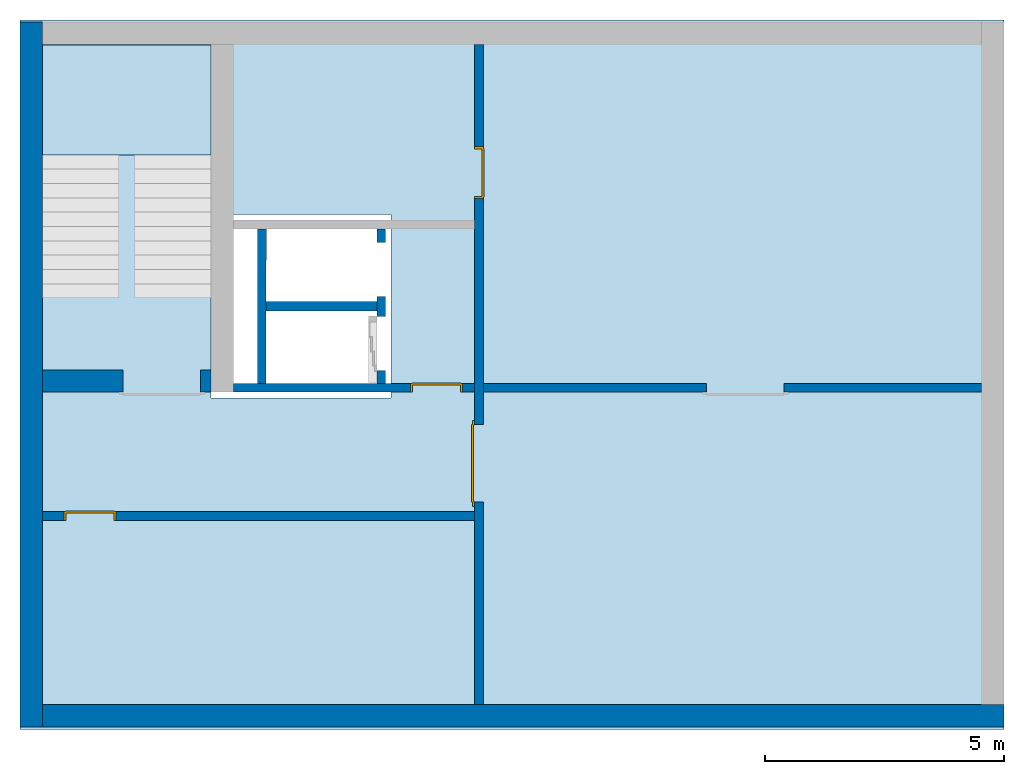
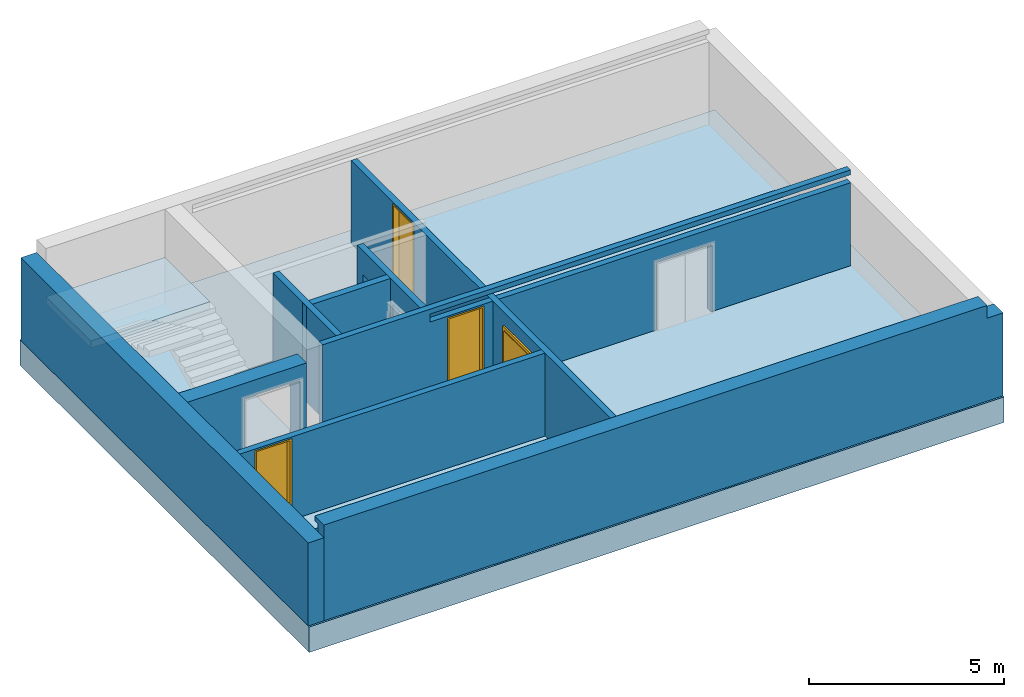
# One storey, part 1 of 3: 9 walls, 4 doors, 1 footing, 1 slab, 8 openings.
"""IFC4 building model written with IfcOpenShell, lengths in metres."""

from ifc_helpers import new_model, entity, si_unit, converted_unit, derived_unit, direction, frame, origin_with_axes, place, context, subcontext, project, spatial, polygons, source, transform, mapped, material, type_object, element, fill, save


model = new_model("IFC4")

# Units and contexts
model_context = context("Model", 3, precision=1e-05, world=origin_with_axes(), true_north=direction((0.0, 1.0)))
body_context = subcontext(model_context, "Body", "Model", "MODEL_VIEW")
ifc_project = project(units=[si_unit("LENGTHUNIT", "METRE"), si_unit("AREAUNIT", "SQUARE_METRE"), si_unit("VOLUMEUNIT", "CUBIC_METRE"), converted_unit("PLANEANGLEUNIT", "DEGREE", entity("IfcPlaneAngleMeasure", 0.0174532925199433), si_unit("PLANEANGLEUNIT", "RADIAN"), dimensions=[0, 0, 0, 0, 0, 0, 0]), converted_unit("TIMEUNIT", "Year", entity("IfcTimeMeasure", 31557600.0), si_unit("TIMEUNIT", "SECOND"), dimensions=[0, 0, 1, 0, 0, 0, 0]), si_unit("MASSUNIT", "GRAM", prefix="KILO"), si_unit("THERMODYNAMICTEMPERATUREUNIT", "DEGREE_CELSIUS"), si_unit("LUMINOUSINTENSITYUNIT", "LUMEN"), si_unit("ENERGYUNIT", "JOULE", prefix="MEGA"), derived_unit("THERMALCONDUCTANCEUNIT", [(si_unit("POWERUNIT", "WATT"), 1), (si_unit("LENGTHUNIT", "METRE"), -1), (si_unit("THERMODYNAMICTEMPERATUREUNIT", "KELVIN"), -1)]), derived_unit("SPECIFICHEATCAPACITYUNIT", [(si_unit("ENERGYUNIT", "JOULE"), 1), (si_unit("MASSUNIT", "GRAM", prefix="KILO"), -1), (si_unit("THERMODYNAMICTEMPERATUREUNIT", "KELVIN"), -1)]), derived_unit("MASSDENSITYUNIT", [(si_unit("MASSUNIT", "GRAM", prefix="KILO"), 1), (si_unit("VOLUMEUNIT", "CUBIC_METRE"), -1)])], contexts=[model_context])

# Site, building, storey
site_placement = place(None, origin_with_axes())
site = spatial("IfcSite", under=ifc_project, at=site_placement, CompositionType="ELEMENT")
building_placement = place(site_placement, origin_with_axes())
building = spatial("IfcBuilding", under=site, at=building_placement, CompositionType="ELEMENT")
storey_placement = place(building_placement, frame((0.0, 0.0, -3.0), z_axis=(0.0, 0.0, 1.0), x_axis=(1.0, 0.0, 0.0)))
storey = spatial("IfcBuildingStorey", under=building, at=storey_placement, Name="UG", CompositionType="ELEMENT", Elevation=-3.0)

# Footing
ifc_material_1 = material(Name="Stahlbeton Decke")
footing_type = type_object("IfcFootingType", Name="Stahlbeton Decke 800", PredefinedType="NOTDEFINED")
footing_placement = place(storey_placement, frame((44.584, 14.845999753475, 0.0), z_axis=(0.0, 0.0, 1.0), x_axis=(1.0, 0.0, 0.0)))
element("IfcFooting", 1, at=footing_placement, inside=storey, type_object=footing_type, material=ifc_material_1, Name="Decke-001", PredefinedType="NOTDEFINED", context=body_context, shape_type="Tessellation", body=[
    polygons([(0.0, 0.0, 0.0), (0.0, 0.0, -0.8), (-20.596, 0.0, -0.8), (-20.596, 0.0, 0.0), (0.0, -14.845999753475, 0.0), (0.0, -14.845999753475, -0.8), (-20.596, -14.845999753475, -0.8), (-12.826, -4.07099980800739, -0.8), (-16.5959999085664, -4.07099980800739, -0.8), (-16.5959999085664, -7.9109998080074, -0.8), (-12.826, -7.9109998080074, -0.8), (-20.596, -14.845999753475, 0.0), (-16.5959999085664, -7.9109998080074, 0.0), (-16.5959999085664, -4.07099980800739, 0.0), (-12.826, -4.07099980800739, 0.0), (-12.826, -7.9109998080074, 0.0)], [[[1, 2, 3, 4]], [[5, 6, 2, 1]], [[3, 2, 6, 7], [8, 9, 10, 11]], [[4, 3, 7, 12]], [[5, 1, 4, 12], [13, 14, 15, 16]], [[12, 7, 6, 5]], [[14, 9, 8, 15]], [[13, 10, 9, 14]], [[16, 11, 10, 13]], [[15, 8, 11, 16]]], closed=True),
])

# Slab
ifc_material_2 = material(Name="Stahlbeton")
slab_type = type_object("IfcSlabType", Name="Stahlbeton 220", PredefinedType="LANDING")
slab_placement = place(storey_placement, frame((24.458, 12.0249999454676, 1.5), z_axis=(0.0, 0.0, 1.0), x_axis=(1.0, 0.0, 0.0)))
element("IfcSlab", 2, at=slab_placement, inside=storey, type_object=slab_type, material=ifc_material_2, Name="Decke-002", PredefinedType="LANDING", context=body_context, shape_type="Tessellation", body=[
    polygons([(0.0, 0.0, 0.0), (0.0, 0.0, -0.22), (3.53, 0.0, -0.22), (3.53, 0.0, 0.0), (0.0, 2.30099994546756, 0.0), (0.0, 2.30099994546756, -0.22), (3.53, 2.30099994546756, -0.22), (3.53, 2.30099994546756, 0.0)], [[[1, 2, 3, 4]], [[5, 6, 2, 1]], [[3, 2, 6, 7]], [[4, 3, 7, 8]], [[5, 1, 4, 8]], [[8, 7, 6, 5]]], closed=True),
])

# Walls
wall_type_1 = type_object("IfcWallType", Name="Stahlbeton 470", PredefinedType="NOTDEFINED")
wall_1_placement = place(storey_placement, frame((24.458, 0.52, 0.0), z_axis=(0.0, 0.0, 1.0), x_axis=(1.0, 0.0, 0.0)))
element("IfcWall", 3, at=wall_1_placement, inside=storey, type_object=wall_type_1, material=ifc_material_2, Name="Wand-002", PredefinedType="NOTDEFINED", context=body_context, shape_type="Tessellation", body=[
    polygons([(19.656, -0.469999999999999, 2.6), (19.656, -0.156999999999999, 2.6), (19.656, -0.156999999999999, 2.85), (19.656, 0.0, 2.85), (19.656, 0.0, 3.0), (19.656, -0.469999999999999, 3.0), (20.126, 0.0, 2.6), (19.656, 0.0, 2.6), (20.126, -0.469999999999999, 2.6), (0.0, -0.156999999999999, 2.85), (0.0, -0.156999999999999, 2.6), (0.0, 0.0, 2.85), (0.0, 0.0, 3.0), (0.0, -0.47, 3.0), (0.0, -0.47, 2.6), (0.0, -0.47, 0.0), (20.126, -0.469999999999999, 0.0), (0.0, 0.0, 0.0), (0.0, 0.0, 2.6), (20.126, 0.0, 0.0)], [[[1, 2, 3, 4, 5, 6]], [[7, 8, 2, 1, 9]], [[10, 3, 2, 11]], [[10, 12, 4, 3]], [[5, 4, 12, 13]], [[5, 13, 14, 6]], [[6, 14, 15, 16, 17, 9, 1]], [[18, 19, 8, 7, 20]], [[11, 2, 8, 19]], [[9, 17, 20, 7]], [[12, 10, 11, 15, 14, 13]], [[15, 11, 19, 18, 16]], [[20, 17, 16, 18]]], closed=True),
])
wall_2_placement = place(storey_placement, frame((24.458, 14.3318657372406, 0.0), z_axis=(0.0, 0.0, 1.0), x_axis=(0.0, -1.0, 0.0)))
element("IfcWall", 4, at=wall_2_placement, inside=storey, type_object=wall_type_1, material=ifc_material_2, Name="Wand-001", PredefinedType="NOTDEFINED", context=body_context, shape_type="Tessellation", body=[
    polygons([(14.2818657372405, -0.469999999999999, 2.6), (14.2818657372405, 0.0, 2.6), (-0.470000000000001, 0.0, 2.6), (-0.469999999999999, -0.469999999999999, 2.6), (14.2818657372405, -0.469999999999999, 0.0), (14.2818657372405, 0.0, 0.0), (-0.470000000000001, 0.0, 0.0), (-0.469999999999999, -0.469999999999999, 0.0)], [[[1, 2, 3, 4]], [[2, 1, 5, 6]], [[2, 6, 7, 3]], [[8, 4, 3, 7]], [[5, 1, 4, 8]], [[6, 5, 8, 7]]], closed=True),
])

# Wall, opening
wall_3_placement = place(storey_placement, frame((27.988, 7.05499994546755, 0.0), z_axis=(0.0, 0.0, 1.0), x_axis=(-1.0, 0.0, 0.0)))
wall_3 = element("IfcWall", 5, at=wall_3_placement, inside=storey, type_object=wall_type_1, material=ifc_material_2, Name="Wand-001", PredefinedType="NOTDEFINED", context=body_context, shape_type="Tessellation", body=[
    polygons([(1.84, -0.470000000000001, 2.11), (1.84, -0.47, 0.0), (3.53, -0.470000000000001, 0.0), (3.53, -0.47, 2.6), (0.0, -0.47, 2.6), (0.0, -0.47, 0.0), (0.219999999999999, -0.47, 0.0), (0.219999999999999, -0.470000000000001, 2.11), (1.84, 0.0, 2.11), (1.84, 0.0, 0.0), (3.53, 0.0, 0.0), (3.53, 0.0, 2.6), (0.0, 0.0, 2.6), (0.0, 0.0, 0.0), (0.219999999999999, 0.0, 0.0), (0.219999999999999, 0.0, 2.11)], [[[1, 2, 3, 4, 5, 6, 7, 8]], [[2, 1, 9, 10]], [[2, 10, 11, 3]], [[4, 3, 11, 12]], [[12, 13, 5, 4]], [[5, 13, 14, 6]], [[15, 7, 6, 14]], [[8, 7, 15, 16]], [[1, 8, 16, 9]], [[16, 15, 14, 13, 12, 11, 10, 9]]], closed=True),
])
opening_1_placement = place(wall_3_placement, frame((1.03, 0.0, 0.0), z_axis=(0.0, 0.0, 1.0), x_axis=(1.0, 0.0, 0.0)))
element("IfcOpeningElement", 6, at=opening_1_placement, cuts=wall_3, context=body_context, identifier="Reference", shape_type="Tessellation", body=[
    polygons([(-0.809999999999999, -0.471, 2.11), (-0.809999999999999, -0.471, 0.0), (0.809999999999999, -0.471, 0.0), (0.809999999999999, -0.471, 2.11), (-0.809999999999999, 0.00100000000000033, 2.11), (-0.809999999999999, 0.00100000000000033, 0.0), (0.809999999999999, 0.00100000000000033, 0.0), (0.809999999999999, 0.00100000000000033, 2.11)], [[[1, 2, 3, 4]], [[5, 6, 2, 1]], [[6, 7, 3, 2]], [[7, 8, 4, 3]], [[8, 5, 1, 4]], [[7, 6, 5, 8]]], closed=True),
])

# Walls
wall_type_2 = type_object("IfcWallType", Name="Stahlbeton 200", PredefinedType="NOTDEFINED")
wall_4_placement = place(storey_placement, frame((28.958, 8.85499994546755, 0.0), z_axis=(0.0, 0.0, 1.0), x_axis=(1.0, 0.0, 0.0)))
element("IfcWall", 7, at=wall_4_placement, inside=storey, type_object=wall_type_2, material=ifc_material_2, Name="Wand-001", PredefinedType="NOTDEFINED", context=body_context, shape_type="Tessellation", body=[
    polygons([(0.00282285620201961, 0.0999999999999996, 0.0), (0.00249458891590848, -0.0999999999999996, 0.0), (0.0, -0.0999999999999996, 0.0), (0.0, 0.0999999999999996, 0.0), (0.00282285620201961, 0.0999999999999996, 3.0), (0.00249458891590848, -0.0999999999999996, 3.0), (0.0, -0.0999999999999996, 3.0), (0.0, 0.0999999999999996, 3.0)], [[[1, 2, 3, 4]], [[2, 1, 5, 6]], [[2, 6, 7, 3]], [[8, 4, 3, 7]], [[5, 1, 4, 8]], [[6, 5, 8, 7]]], closed=True),
    polygons([(2.5, 0.0999999999999996, 0.0), (2.5, -0.0999999999999996, 0.0), (0.18249483137442, -0.0999999999999996, 0.0), (0.182823098660531, 0.0999999999999996, 0.0), (2.5, 0.0999999999999996, 3.0), (2.5, -0.0999999999999996, 3.0), (0.18249483137442, -0.0999999999999996, 3.0), (0.182823098660531, 0.0999999999999996, 3.0)], [[[1, 2, 3, 4]], [[2, 1, 5, 6]], [[2, 6, 7, 3]], [[8, 4, 3, 7]], [[5, 1, 4, 8]], [[6, 5, 8, 7]]], closed=True),
])
wall_type_3 = type_object("IfcWallType", Name="Stahlbeton 180", PredefinedType="NOTDEFINED")
wall_5_placement = place(storey_placement, frame((29.1377045594425, 7.05499994546755, 0.0), z_axis=(0.0, 0.0, 1.0), x_axis=(0.00164133421967425, 0.999998653010083, 0.0)))
element("IfcWall", 8, at=wall_5_placement, inside=storey, type_object=wall_type_3, material=ifc_material_2, Name="Wand-001", PredefinedType="NOTDEFINED", context=body_context, shape_type="Tessellation", body=[
    polygons([(0.179704801901014, 0.18, 0.0), (3.41970916615423, 0.180000000000007, 0.0), (3.42000460671172, 0.0, 0.0), (0.180000242458512, 0.0, 0.0), (0.179704801901014, 0.18, 3.0), (3.41970916615423, 0.180000000000007, 3.0), (3.42000460671172, 0.0, 3.0), (0.180000242458512, 0.0, 3.0)], [[[1, 2, 3, 4]], [[5, 6, 2, 1]], [[7, 3, 2, 6]], [[4, 3, 7, 8]], [[8, 5, 1, 4]], [[8, 7, 6, 5]]], closed=True),
])

# Wall, openings, doors
wall_6_placement = place(storey_placement, frame((33.505, 14.3318657372406, 0.0), z_axis=(0.0, 0.0, 1.0), x_axis=(0.0, -1.0, 0.0)))
wall_6 = element("IfcWall", 9, at=wall_6_placement, inside=storey, type_object=wall_type_3, material=ifc_material_2, Name="Wand-001", PredefinedType="NOTDEFINED", context=body_context, shape_type="Tessellation", body=[
    polygons([(3.22686579177299, 0.18, 0.0), (3.22686579177299, 0.18, 2.545), (2.13686579177299, 0.18, 2.545), (2.13686579177299, 0.18, 0.0), (0.0, 0.18, 0.0), (0.0, 0.18, 2.6), (13.8118657372406, 0.18, 2.6), (13.8118657372406, 0.18, 0.0), (9.57686579177299, 0.18, 0.0), (9.57686579177299, 0.18, 2.11), (7.95686579177299, 0.18, 2.11), (7.95686579177299, 0.18, 0.0), (3.22686579177299, 0.0, 0.0), (3.22686579177299, 0.0, 2.545), (2.13686579177299, 0.0, 2.545), (2.13686579177299, 0.0, 0.0), (0.0, 0.0, 0.0), (0.0, 0.0, 2.6), (13.8118657372406, 0.0, 2.6), (13.8118657372406, 0.0, 0.0), (9.57686579177299, 0.0, 0.0), (9.57686579177299, 0.0, 2.11), (7.95686579177299, 0.0, 2.11), (7.95686579177299, 0.0, 0.0)], [[[1, 2, 3, 4, 5, 6, 7, 8, 9, 10, 11, 12]], [[2, 1, 13, 14]], [[3, 2, 14, 15]], [[4, 3, 15, 16]], [[4, 16, 17, 5]], [[17, 18, 6, 5]], [[6, 18, 19, 7]], [[7, 19, 20, 8]], [[9, 8, 20, 21]], [[9, 21, 22, 10]], [[10, 22, 23, 11]], [[11, 23, 24, 12]], [[13, 1, 12, 24]], [[14, 13, 24, 23, 22, 21, 20, 19, 18, 17, 16, 15]]], closed=True),
])
opening_2_placement = place(wall_6_placement, frame((8.76686579177299, 0.0, 0.0), z_axis=(0.0, 0.0, 1.0), x_axis=(1.0, 0.0, 0.0)))
opening_2 = element("IfcOpeningElement", 10, at=opening_2_placement, cuts=wall_6, context=body_context, identifier="Reference", shape_type="Tessellation", body=[
    polygons([(0.81, 0.180999999999997, 2.11), (0.81, 0.180999999999997, 0.0), (-0.81, 0.180999999999997, 0.0), (-0.81, 0.180999999999997, 2.11), (0.81, -0.000999999999997669, 2.11), (0.81, -0.000999999999997669, 0.0), (-0.81, -0.000999999999997669, 0.0), (-0.81, -0.000999999999997669, 2.11)], [[[1, 2, 3, 4]], [[5, 6, 2, 1]], [[6, 7, 3, 2]], [[7, 8, 4, 3]], [[8, 5, 1, 4]], [[7, 6, 5, 8]]], closed=True),
])
opening_3_placement = place(wall_6_placement, frame((2.68186579177299, 0.0, 0.0), z_axis=(0.0, 0.0, 1.0), x_axis=(1.0, 0.0, 0.0)))
opening_3 = element("IfcOpeningElement", 11, at=opening_3_placement, cuts=wall_6, context=body_context, identifier="Reference", shape_type="Tessellation", body=[
    polygons([(-0.545, -0.000999999999997669, 2.545), (-0.545, -0.000999999999997669, 0.0), (0.545, -0.000999999999997669, 0.0), (0.545, -0.000999999999997669, 2.545), (-0.545, 0.180999999999997, 2.545), (-0.545, 0.180999999999997, 0.0), (0.545, 0.180999999999997, 0.0), (0.545, 0.180999999999997, 2.545)], [[[1, 2, 3, 4]], [[5, 6, 2, 1]], [[6, 7, 3, 2]], [[7, 8, 4, 3]], [[8, 5, 1, 4]], [[7, 6, 5, 8]]], closed=True),
])
door_type_1 = type_object("IfcDoorType", OperationType="DOUBLE_DOOR_SINGLE_SWING", PredefinedType="DOOR")
shared_shape = source(origin_with_axes(), body_context, "Body", "Tessellation", [
    polygons([(-0.9, 0.0, 0.0), (-0.9, 0.0, 2.2), (-0.9, 0.03, 2.2), (-0.9, 0.03, 0.0), (-0.8, 0.0, 0.0), (-0.8, 0.0, 2.1), (-0.1101, 0.0, 2.1), (-0.0001, 0.0, 2.1), (0.8, 0.0, 2.1), (0.8, 0.0, 0.0), (0.9, 0.0, 0.0), (0.9, 0.0, 2.2), (0.9, 0.03, 2.2), (0.9, 0.03, 0.0), (0.8, 0.03, 0.0), (0.8, 0.03, 2.1), (-0.0001, 0.03, 2.1), (-0.1101, 0.03, 2.1), (-0.8, 0.03, 2.1), (-0.8, 0.03, 0.0)], [[[1, 2, 3, 4]], [[1, 5, 6, 7, 8, 9, 10, 11, 12, 2]], [[2, 12, 13, 3]], [[4, 3, 13, 14, 15, 16, 17, 18, 19, 20]], [[5, 1, 4, 20]], [[6, 5, 20, 19]], [[7, 6, 19, 18]], [[8, 7, 18, 17]], [[9, 8, 17, 16]], [[10, 9, 16, 15]], [[11, 10, 15, 14]], [[12, 11, 14, 13]]], closed=True),
    polygons([(-0.9, 0.03, 0.0), (-0.9, 0.03, 2.2), (-0.9, 0.05, 2.2), (-0.9, 0.05, 0.0), (-0.81, 0.03, 0.0), (-0.81, 0.03, 2.11), (-0.1001, 0.03, 2.11), (-0.0101, 0.03, 2.11), (0.81, 0.03, 2.11), (0.81, 0.03, 0.0), (0.9, 0.03, 0.0), (0.9, 0.03, 2.2), (0.9, 0.05, 2.2), (0.9, 0.05, 0.0), (0.81, 0.05, 0.0), (0.81, 0.05, 2.11), (-0.0101, 0.05, 2.11), (-0.1001, 0.05, 2.11), (-0.81, 0.05, 2.11), (-0.81, 0.05, 0.0)], [[[1, 2, 3, 4]], [[1, 5, 6, 7, 8, 9, 10, 11, 12, 2]], [[2, 12, 13, 3]], [[4, 3, 13, 14, 15, 16, 17, 18, 19, 20]], [[5, 1, 4, 20]], [[6, 5, 20, 19]], [[7, 6, 19, 18]], [[8, 7, 18, 17]], [[9, 8, 17, 16]], [[10, 9, 16, 15]], [[11, 10, 15, 14]], [[12, 11, 14, 13]]], closed=True),
    polygons([(-0.81, 0.07, 0.0), (-0.81, 0.07, 2.11), (-0.000499999999999945, 0.07, 2.11), (-0.000499999999999945, 0.07, 0.0), (-0.81, 0.03, 0.0), (-0.81, 0.03, 2.11), (-0.000499999999999945, 0.03, 2.11), (-0.000499999999999945, 0.03, 0.0)], [[[1, 2, 3, 4]], [[1, 5, 6, 2]], [[2, 6, 7, 3]], [[3, 7, 8, 4]], [[4, 8, 5, 1]], [[8, 7, 6, 5]]], closed=True),
    polygons([(0.81, 0.07, 0.0), (0.000499999999999945, 0.07, 0.0), (0.000499999999999945, 0.07, 2.11), (0.81, 0.07, 2.11), (0.81, 0.03, 0.0), (0.000499999999999945, 0.03, 0.0), (0.000499999999999945, 0.03, 2.11), (0.81, 0.03, 2.11)], [[[1, 2, 3, 4]], [[2, 1, 5, 6]], [[3, 2, 6, 7]], [[4, 3, 7, 8]], [[1, 4, 8, 5]], [[6, 5, 8, 7]]], closed=True),
])
door_1_placement = place(opening_2_placement, frame((0.8, 0.0, 0.0), z_axis=(0.0, 0.0, 1.0), x_axis=(-1.0, 0.0, 0.0)))
door_1 = element("IfcDoor", 12, at=door_1_placement, inside=storey, type_object=door_type_1, OverallHeight=2.11, OverallWidth=1.62, PredefinedType="DOOR", context=body_context, shape_type="MappedRepresentation", body=[
    mapped(shared_shape, transform((0.8, 0.0, 0.0))),
])
fill(opening_2, door_1)
door_type_2 = type_object("IfcDoorType", Name="27", OperationType="SINGLE_SWING_LEFT", PredefinedType="DOOR")
door_2_placement = place(opening_3_placement, frame((-0.5, 0.0, 0.0), z_axis=(0.0, 0.0, 1.0), x_axis=(1.0, 0.0, 0.0)))
door_2 = element("IfcDoor", 13, at=door_2_placement, inside=storey, type_object=door_type_2, OverallHeight=2.545, OverallWidth=1.09, PredefinedType="DOOR", context=body_context, shape_type="Tessellation", body=[
    polygons([(-0.0449999999999999, 0.0, 0.0), (-0.0449999999999999, 0.0, 2.545), (-0.0449999999999999, 0.155000000000001, 2.545), (-0.0449999999999999, 0.155000000000001, 0.0), (0.0, 0.0, 0.0), (0.0, 0.0, 2.5), (0.444900000000001, 0.0, 2.5), (0.4999, 0.0, 2.5), (1.0, 0.0, 2.5), (1.0, 0.0, 0.0), (1.045, 0.0, 0.0), (1.045, 0.0, 2.545), (1.045, 0.155000000000001, 2.545), (1.045, 0.155000000000001, 0.0), (1.0, 0.155000000000001, 0.0), (1.0, 0.155000000000001, 2.5), (0.4999, 0.155000000000001, 2.5), (0.444900000000001, 0.155000000000001, 2.5), (0.0, 0.155000000000001, 2.5), (0.0, 0.155000000000001, 0.0)], [[[1, 2, 3, 4]], [[1, 5, 6, 7, 8, 9, 10, 11, 12, 2]], [[2, 12, 13, 3]], [[4, 3, 13, 14, 15, 16, 17, 18, 19, 20]], [[5, 1, 4, 20]], [[6, 5, 20, 19]], [[7, 6, 19, 18]], [[8, 7, 18, 17]], [[9, 8, 17, 16]], [[10, 9, 16, 15]], [[11, 10, 15, 14]], [[12, 11, 14, 13]]], closed=True),
    polygons([(-0.0449999999999999, 0.155000000000001, 0.0), (-0.0449999999999999, 0.155000000000001, 2.545), (-0.0449999999999999, 0.18, 2.545), (-0.0449999999999999, 0.18, 0.0), (-0.00999999999999979, 0.155000000000001, 0.0), (-0.00999999999999979, 0.155000000000001, 2.51), (0.4549, 0.155000000000001, 2.51), (0.4899, 0.155000000000001, 2.51), (1.01, 0.155000000000001, 2.51), (1.01, 0.155000000000001, 0.0), (1.045, 0.155000000000001, 0.0), (1.045, 0.155000000000001, 2.545), (1.045, 0.18, 2.545), (1.045, 0.18, 0.0), (1.01, 0.18, 0.0), (1.01, 0.18, 2.51), (0.4899, 0.18, 2.51), (0.4549, 0.18, 2.51), (-0.00999999999999979, 0.18, 2.51), (-0.00999999999999979, 0.18, 0.0)], [[[1, 2, 3, 4]], [[1, 5, 6, 7, 8, 9, 10, 11, 12, 2]], [[2, 12, 13, 3]], [[4, 3, 13, 14, 15, 16, 17, 18, 19, 20]], [[5, 1, 4, 20]], [[6, 5, 20, 19]], [[7, 6, 19, 18]], [[8, 7, 18, 17]], [[9, 8, 17, 16]], [[10, 9, 16, 15]], [[11, 10, 15, 14]], [[12, 11, 14, 13]]], closed=True),
    polygons([(-0.00999999999999979, 0.195, 0.0), (-0.00999999999999979, 0.195, 2.51), (1.01, 0.195, 2.51), (1.01, 0.195, 0.0), (-0.00999999999999979, 0.155000000000001, 0.0), (-0.00999999999999979, 0.155000000000001, 2.51), (1.01, 0.155000000000001, 2.51), (1.01, 0.155000000000001, 0.0)], [[[1, 2, 3, 4]], [[1, 5, 6, 2]], [[2, 6, 7, 3]], [[3, 7, 8, 4]], [[4, 8, 5, 1]], [[8, 7, 6, 5]]], closed=True),
])
fill(opening_3, door_2)

# Wall, opening, door
wall_7_placement = place(storey_placement, frame((33.505, 4.55499994546755, 0.0), z_axis=(0.0, 0.0, 1.0), x_axis=(-1.0, 0.0, 0.0)))
wall_7 = element("IfcWall", 14, at=wall_7_placement, inside=storey, type_object=wall_type_3, material=ifc_material_2, Name="Wand-003", PredefinedType="NOTDEFINED", context=body_context, shape_type="Tessellation", body=[
    polygons([(8.59699999999999, 0.0, 2.545), (8.59699999999999, 0.0, 0.0), (9.047, 0.0, 0.0), (9.047, 0.0, 2.6), (0.0, 0.0, 2.6), (0.0, 0.0, 0.0), (7.507, 0.0, 0.0), (7.507, 0.0, 2.545), (8.59699999999999, 0.18, 2.545), (8.59699999999999, 0.18, 0.0), (9.047, 0.18, 0.0), (9.047, 0.18, 2.6), (0.0, 0.180000000000001, 2.6), (0.0, 0.18, 0.0), (7.507, 0.18, 0.0), (7.507, 0.18, 2.545)], [[[1, 2, 3, 4, 5, 6, 7, 8]], [[2, 1, 9, 10]], [[2, 10, 11, 3]], [[11, 12, 4, 3]], [[12, 13, 5, 4]], [[14, 6, 5, 13]], [[15, 7, 6, 14]], [[8, 7, 15, 16]], [[1, 8, 16, 9]], [[16, 15, 14, 13, 12, 11, 10, 9]]], closed=True),
])
opening_4_placement = place(wall_7_placement, frame((8.052, 0.0, 0.0), z_axis=(0.0, 0.0, 1.0), x_axis=(1.0, 0.0, 0.0)))
opening_4 = element("IfcOpeningElement", 15, at=opening_4_placement, cuts=wall_7, context=body_context, identifier="Reference", shape_type="Tessellation", body=[
    polygons([(-0.544999999999998, -0.00100000000000033, 2.545), (-0.544999999999998, -0.00100000000000033, 0.0), (0.544999999999998, -0.00100000000000033, 0.0), (0.544999999999998, -0.00100000000000033, 2.545), (-0.544999999999998, 0.181, 2.545), (-0.544999999999998, 0.181, 0.0), (0.544999999999998, 0.181, 0.0), (0.544999999999998, 0.181, 2.545)], [[[1, 2, 3, 4]], [[5, 6, 2, 1]], [[6, 7, 3, 2]], [[7, 8, 4, 3]], [[8, 5, 1, 4]], [[7, 6, 5, 8]]], closed=True),
])
door_3_placement = place(opening_4_placement, frame((0.5, 0.0, 0.0), z_axis=(0.0, 0.0, 1.0), x_axis=(-1.0, 0.0, 0.0)))
door_3 = element("IfcDoor", 16, at=door_3_placement, inside=storey, type_object=door_type_2, OverallHeight=2.545, OverallWidth=1.09, PredefinedType="DOOR", context=body_context, shape_type="Tessellation", body=[
    polygons([(-0.0449999999999982, -0.179999999999999, 0.0), (-0.0449999999999982, -0.179999999999999, 2.545), (-0.0449999999999982, -0.0249999999999995, 2.545), (-0.0449999999999982, -0.0249999999999986, 0.0), (0.0, -0.179999999999999, 0.0), (0.0, -0.179999999999999, 2.5), (0.444900000000001, -0.179999999999999, 2.5), (0.4999, -0.179999999999999, 2.5), (1.0, -0.18, 2.5), (1.0, -0.179999999999999, 0.0), (1.045, -0.179999999999999, 0.0), (1.045, -0.18, 2.545), (1.045, -0.0249999999999995, 2.545), (1.045, -0.0249999999999995, 0.0), (1.0, -0.0249999999999995, 0.0), (1.0, -0.0249999999999995, 2.5), (0.4999, -0.0249999999999995, 2.5), (0.444900000000001, -0.0249999999999995, 2.5), (0.0, -0.0249999999999995, 2.5), (0.0, -0.0249999999999986, 0.0)], [[[1, 2, 3, 4]], [[1, 5, 6, 7, 8, 9, 10, 11, 12, 2]], [[2, 12, 13, 3]], [[4, 3, 13, 14, 15, 16, 17, 18, 19, 20]], [[5, 1, 4, 20]], [[6, 5, 20, 19]], [[7, 6, 19, 18]], [[8, 7, 18, 17]], [[9, 8, 17, 16]], [[10, 9, 16, 15]], [[11, 10, 15, 14]], [[12, 11, 14, 13]]], closed=True),
    polygons([(-0.0449999999999982, -0.0249999999999986, 0.0), (-0.0449999999999982, -0.0249999999999995, 2.545), (-0.0449999999999982, 0.0, 2.545), (-0.0449999999999982, 0.0, 0.0), (-0.0100000000000016, -0.0249999999999986, 0.0), (-0.0100000000000016, -0.0249999999999995, 2.51), (0.454899999999999, -0.0249999999999995, 2.51), (0.489899999999999, -0.0249999999999995, 2.51), (1.01, -0.0249999999999995, 2.51), (1.01, -0.0249999999999995, 0.0), (1.045, -0.0249999999999995, 0.0), (1.045, -0.0249999999999995, 2.545), (1.045, 0.0, 2.545), (1.045, 0.0, 0.0), (1.01, 0.0, 0.0), (1.01, 0.0, 2.51), (0.489899999999999, 0.0, 2.51), (0.454899999999999, 0.0, 2.51), (-0.0100000000000016, 0.0, 2.51), (-0.0100000000000016, 0.0, 0.0)], [[[1, 2, 3, 4]], [[1, 5, 6, 7, 8, 9, 10, 11, 12, 2]], [[2, 12, 13, 3]], [[4, 3, 13, 14, 15, 16, 17, 18, 19, 20]], [[5, 1, 4, 20]], [[6, 5, 20, 19]], [[7, 6, 19, 18]], [[8, 7, 18, 17]], [[9, 8, 17, 16]], [[10, 9, 16, 15]], [[11, 10, 15, 14]], [[12, 11, 14, 13]]], closed=True),
    polygons([(-0.0100000000000016, 0.0150000000000015, 0.0), (-0.0100000000000016, 0.0150000000000006, 2.51), (1.01, 0.0150000000000006, 2.51), (1.01, 0.0150000000000006, 0.0), (-0.0100000000000016, -0.0249999999999986, 0.0), (-0.0100000000000016, -0.0249999999999995, 2.51), (1.01, -0.0249999999999995, 2.51), (1.01, -0.0249999999999995, 0.0)], [[[1, 2, 3, 4]], [[1, 5, 6, 2]], [[2, 6, 7, 3]], [[3, 7, 8, 4]], [[4, 8, 5, 1]], [[8, 7, 6, 5]]], closed=True),
])
fill(opening_4, door_3)

# Wall, openings
wall_8_placement = place(storey_placement, frame((31.638, 7.05499994546755, 0.0), z_axis=(0.0, 0.0, 1.0), x_axis=(0.0, 1.0, 0.0)))
wall_8 = element("IfcWall", 17, at=wall_8_placement, inside=storey, type_object=wall_type_3, material=ifc_material_2, Name="Wand-002", PredefinedType="NOTDEFINED", context=body_context, shape_type="Tessellation", body=[
    polygons([(2.0, 0.0, 0.0), (2.0, 0.0, 2.25), (3.13, 0.0, 2.25), (3.13, 0.0, 0.0), (3.42, 0.0, 0.0), (3.42, 0.0, 3.0), (0.179999999999999, 0.0, 3.0), (0.179999999999999, 0.0, 0.0), (0.450000000000002, 0.0, 0.0), (0.450000000000002, 0.0, 2.25), (1.58, 0.0, 2.25), (1.58, 0.0, 0.0), (2.0, 0.179999999999996, 0.0), (2.0, 0.179999999999996, 2.25), (3.13, 0.179999999999996, 2.25), (3.13, 0.179999999999996, 0.0), (3.42, 0.179999999999996, 0.0), (3.42, 0.179999999999996, 3.0), (0.179999999999999, 0.18, 3.0), (0.179999999999999, 0.18, 0.0), (0.450000000000002, 0.18, 0.0), (0.450000000000002, 0.18, 2.25), (1.58, 0.18, 2.25), (1.58, 0.18, 0.0)], [[[1, 2, 3, 4, 5, 6, 7, 8, 9, 10, 11, 12]], [[2, 1, 13, 14]], [[3, 2, 14, 15]], [[4, 3, 15, 16]], [[4, 16, 17, 5]], [[18, 6, 5, 17]], [[19, 7, 6, 18]], [[8, 7, 19, 20]], [[9, 8, 20, 21]], [[9, 21, 22, 10]], [[10, 22, 23, 11]], [[11, 23, 24, 12]], [[13, 1, 12, 24]], [[14, 13, 24, 23, 22, 21, 20, 19, 18, 17, 16, 15]]], closed=True),
])
opening_5_placement = place(wall_8_placement, frame((1.015, 0.0, 0.0), z_axis=(0.0, 0.0, 1.0), x_axis=(1.0, 0.0, 0.0)))
element("IfcOpeningElement", 18, at=opening_5_placement, cuts=wall_8, context=body_context, identifier="Reference", shape_type="Tessellation", body=[
    polygons([(-0.565, -0.00100000000000122, 2.25), (-0.565, -0.00100000000000122, 0.0), (0.565, -0.00100000000000122, 0.0), (0.565, -0.00100000000000122, 2.25), (-0.565, 0.181000000000004, 2.25), (-0.565, 0.181000000000004, 0.0), (0.565000000000001, 0.181000000000004, 0.0), (0.565000000000001, 0.181000000000004, 2.25)], [[[1, 2, 3, 4]], [[5, 6, 2, 1]], [[6, 7, 3, 2]], [[7, 8, 4, 3]], [[8, 5, 1, 4]], [[7, 6, 5, 8]]], closed=True),
])
opening_6_placement = place(wall_8_placement, frame((2.565, 0.0, 0.0), z_axis=(0.0, 0.0, 1.0), x_axis=(1.0, 0.0, 0.0)))
element("IfcOpeningElement", 19, at=opening_6_placement, cuts=wall_8, context=body_context, identifier="Reference", shape_type="Tessellation", body=[
    polygons([(-0.565, -0.00100000000000478, 2.25), (-0.565, -0.00100000000000478, 0.0), (0.565, -0.00100000000000478, 0.0), (0.565, -0.00100000000000478, 2.25), (-0.564999999999998, 0.181000000000001, 2.25), (-0.564999999999998, 0.181000000000001, 0.0), (0.565000000000001, 0.181000000000001, 0.0), (0.565000000000001, 0.181000000000001, 2.25)], [[[1, 2, 3, 4]], [[5, 6, 2, 1]], [[6, 7, 3, 2]], [[7, 8, 4, 3]], [[8, 5, 1, 4]], [[7, 6, 5, 8]]], closed=True),
])

# Wall, openings, door
wall_9_placement = place(storey_placement, frame((27.988, 7.05499994546755, 0.0), z_axis=(0.0, 0.0, 1.0), x_axis=(1.0, 0.0, 0.0)))
wall_9 = element("IfcWall", 20, at=wall_9_placement, inside=storey, type_object=wall_type_3, material=ifc_material_2, Name="Wand-001", PredefinedType="NOTDEFINED", context=body_context, shape_type="Tessellation", body=[
    polygons([(10.370657642847, 0.18, 2.11), (10.370657642847, 0.18, 0.0), (5.69699999999999, 0.18, 0.0), (5.69699999999999, 0.180000000000002, 2.6), (8.20499999999999, 0.180000000000002, 2.6), (16.126, 0.180000000000001, 2.6), (16.126, 0.180000000000001, 0.0), (11.990657642847, 0.180000000000001, 0.0), (11.990657642847, 0.180000000000001, 2.11), (10.370657642847, 0.0, 2.11), (10.370657642847, 0.0, 0.0), (5.69699999999999, 0.0, 0.0), (5.69699999999999, 0.0, 2.6), (16.126, 0.0, 2.6), (16.126, 0.0, 0.0), (11.990657642847, 0.0, 0.0), (11.990657642847, 0.0, 2.11)], [[[1, 2, 3, 4, 5, 6, 7, 8, 9]], [[2, 1, 10, 11]], [[2, 11, 12, 3]], [[13, 4, 3, 12]], [[4, 13, 14, 6, 5]], [[6, 14, 15, 7]], [[16, 8, 7, 15]], [[9, 8, 16, 17]], [[1, 9, 17, 10]], [[17, 16, 15, 14, 13, 12, 11, 10]]], closed=True),
    polygons([(4.17199999999999, 0.18, 2.545), (4.17199999999999, 0.18, 0.0), (0.469999999999999, 0.18, 0.0), (0.469999999999999, 0.180000000000001, 3.0), (16.126, 0.180000000000001, 3.0), (16.126, 0.180000000000001, 2.85), (8.20499999999999, 0.180000000000002, 2.85), (5.69699999999999, 0.180000000000002, 2.85), (3.65000002908709, 0.18, 2.85), (3.65000002908709, 0.18, 2.6), (5.51699999999999, 0.18, 2.6), (5.51699999999999, 0.18, 0.0), (5.262, 0.18, 0.0), (5.262, 0.18, 2.545), (4.17199999999999, 1.29097926127031e-07, 2.545), (4.17199999999999, 0.0, 0.0), (0.469999999999999, 0.0, 0.0), (0.469999999999999, 0.0, 2.6), (0.469999999999999, 0.0, 3.0), (16.126, 0.0, 3.0), (16.126, 0.0, 2.85), (3.65000002908709, 1.29097926127031e-07, 2.85), (3.65000002908709, 1.29097926127031e-07, 2.6), (5.51699999999999, 0.0, 2.6), (5.51699999999999, 0.0, 0.0), (5.262, 0.0, 0.0), (5.262, 1.29097926127031e-07, 2.545)], [[[1, 2, 3, 4, 5, 6, 7, 8, 9, 10, 11, 12, 13, 14]], [[2, 1, 15, 16]], [[2, 16, 17, 3]], [[3, 17, 18, 19, 4]], [[5, 4, 19, 20]], [[21, 6, 5, 20]], [[6, 21, 22, 9, 8, 7]], [[10, 9, 22, 23]], [[24, 11, 10, 23]], [[11, 24, 25, 12]], [[26, 13, 12, 25]], [[14, 13, 26, 27]], [[1, 14, 27, 15]], [[27, 26, 25, 24, 23, 22, 21, 20, 19, 18, 17, 16, 15]]], closed=True),
])
opening_7_placement = place(wall_9_placement, frame((4.717, 0.0, 0.0), z_axis=(0.0, 0.0, 1.0), x_axis=(1.0, 0.0, 0.0)))
opening_7 = element("IfcOpeningElement", 21, at=opening_7_placement, cuts=wall_9, context=body_context, identifier="Reference", shape_type="Tessellation", body=[
    polygons([(-0.545000000000002, -0.00100000000000033, 2.545), (-0.545000000000002, -0.00100000000000033, 0.0), (0.545000000000002, -0.00100000000000033, 0.0), (0.545000000000002, -0.00100000000000033, 2.545), (-0.545000000000002, 0.181, 2.545), (-0.545000000000002, 0.181, 0.0), (0.545000000000002, 0.181, 0.0), (0.545000000000002, 0.181, 2.545)], [[[1, 2, 3, 4]], [[5, 6, 2, 1]], [[6, 7, 3, 2]], [[7, 8, 4, 3]], [[8, 5, 1, 4]], [[7, 6, 5, 8]]], closed=True),
])
opening_8_placement = place(wall_9_placement, frame((11.180657642847, 0.0, 0.0), z_axis=(0.0, 0.0, 1.0), x_axis=(1.0, 0.0, 0.0)))
element("IfcOpeningElement", 22, at=opening_8_placement, cuts=wall_9, context=body_context, identifier="Reference", shape_type="Tessellation", body=[
    polygons([(0.810000000000002, 0.181000000000002, 2.11), (0.810000000000002, 0.181000000000002, 0.0), (-0.810000000000002, 0.181000000000002, 0.0), (-0.810000000000002, 0.181000000000003, 2.11), (0.810000000000002, -0.00100000000000478, 2.11), (0.810000000000002, -0.00100000000000478, 0.0), (-0.810000000000002, -0.00100000000000478, 0.0), (-0.810000000000002, -0.00100000000000389, 2.11)], [[[1, 2, 3, 4]], [[5, 6, 2, 1]], [[6, 7, 3, 2]], [[7, 8, 4, 3]], [[8, 5, 1, 4]], [[7, 6, 5, 8]]], closed=True),
])
door_type_3 = type_object("IfcDoorType", Name="27", OperationType="SINGLE_SWING_RIGHT", PredefinedType="DOOR")
door_4_placement = place(opening_7_placement, frame((-0.5, 0.0, 0.0), z_axis=(0.0, 0.0, 1.0), x_axis=(1.0, 0.0, 0.0)))
door_4 = element("IfcDoor", 23, at=door_4_placement, inside=storey, type_object=door_type_3, OverallHeight=2.545, OverallWidth=1.09, PredefinedType="DOOR", context=body_context, shape_type="Tessellation", body=[
    polygons([(1.045, 0.0, 0.0), (1.045, 0.154999999999999, 0.0), (1.045, 0.155, 2.545), (1.045, 0.0, 2.545), (1.0, 0.0, 0.0), (1.0, 0.154999999999999, 0.0), (1.0, 0.155, 2.5), (0.555100000000003, 0.155, 2.5), (0.500100000000003, 0.155, 2.5), (0.0, 0.155, 2.5), (0.0, 0.154999999999999, 0.0), (-0.0450000000000017, 0.154999999999999, 0.0), (-0.0450000000000017, 0.155, 2.545), (-0.0450000000000017, 0.0, 2.545), (-0.0450000000000017, 0.0, 0.0), (0.0, 0.0, 0.0), (0.0, 0.0, 2.5), (0.500100000000003, 0.0, 2.5), (0.555100000000003, 0.0, 2.5), (1.0, 0.0, 2.5)], [[[1, 2, 3, 4]], [[5, 6, 2, 1]], [[2, 6, 7, 8, 9, 10, 11, 12, 13, 3]], [[4, 3, 13, 14]], [[1, 4, 14, 15, 16, 17, 18, 19, 20, 5]], [[20, 7, 6, 5]], [[19, 8, 7, 20]], [[18, 9, 8, 19]], [[17, 10, 9, 18]], [[16, 11, 10, 17]], [[15, 12, 11, 16]], [[14, 13, 12, 15]]], closed=True),
    polygons([(1.045, 0.154999999999999, 0.0), (1.045, 0.18, 0.0), (1.045, 0.18, 2.545), (1.045, 0.155, 2.545), (1.01, 0.154999999999999, 0.0), (1.01, 0.18, 0.0), (1.01, 0.18, 2.51), (0.545099999999998, 0.18, 2.51), (0.510100000000001, 0.18, 2.51), (-0.00999999999999801, 0.18, 2.51), (-0.00999999999999801, 0.18, 0.0), (-0.0450000000000017, 0.18, 0.0), (-0.0450000000000017, 0.18, 2.545), (-0.0450000000000017, 0.155, 2.545), (-0.0450000000000017, 0.154999999999999, 0.0), (-0.00999999999999801, 0.154999999999999, 0.0), (-0.00999999999999801, 0.155, 2.51), (0.510100000000001, 0.155, 2.51), (0.545099999999998, 0.155, 2.51), (1.01, 0.155, 2.51)], [[[1, 2, 3, 4]], [[5, 6, 2, 1]], [[2, 6, 7, 8, 9, 10, 11, 12, 13, 3]], [[4, 3, 13, 14]], [[1, 4, 14, 15, 16, 17, 18, 19, 20, 5]], [[20, 7, 6, 5]], [[19, 8, 7, 20]], [[18, 9, 8, 19]], [[17, 10, 9, 18]], [[16, 11, 10, 17]], [[15, 12, 11, 16]], [[14, 13, 12, 15]]], closed=True),
    polygons([(1.01, 0.194999999999999, 0.0), (-0.00999999999999801, 0.194999999999999, 0.0), (-0.00999999999999801, 0.195, 2.51), (1.01, 0.195, 2.51), (1.01, 0.154999999999999, 0.0), (-0.00999999999999801, 0.154999999999999, 0.0), (-0.00999999999999801, 0.155, 2.51), (1.01, 0.155, 2.51)], [[[1, 2, 3, 4]], [[2, 1, 5, 6]], [[3, 2, 6, 7]], [[4, 3, 7, 8]], [[1, 4, 8, 5]], [[6, 5, 8, 7]]], closed=True),
])
fill(opening_7, door_4)

save(model, "model.ifc")
